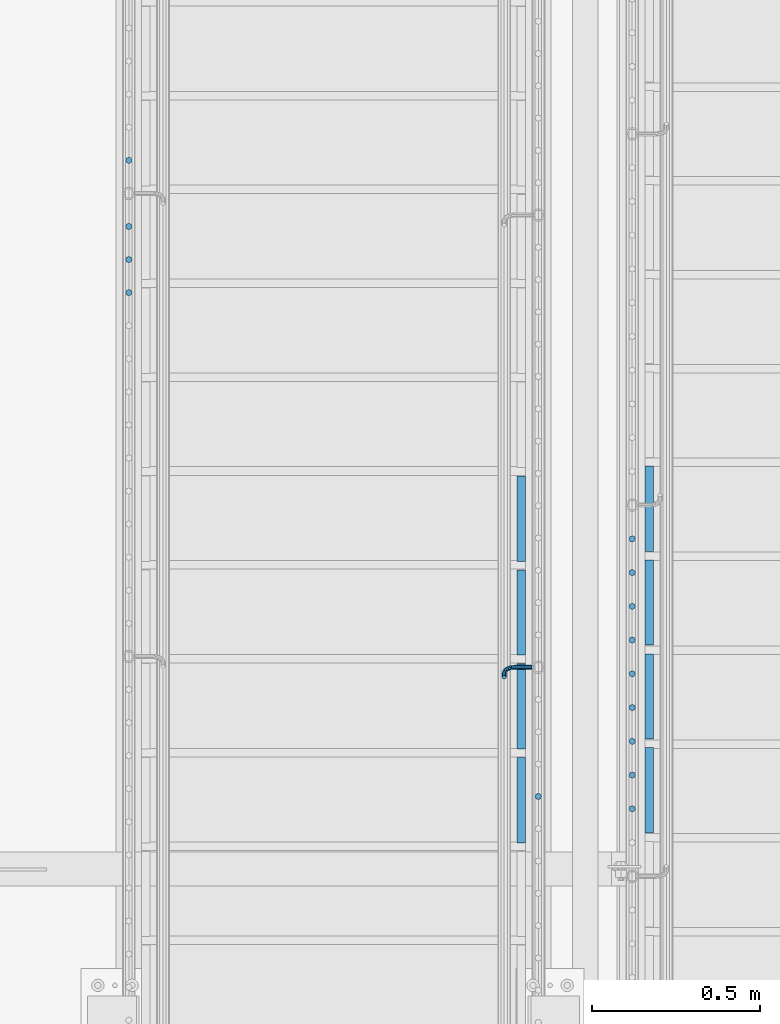
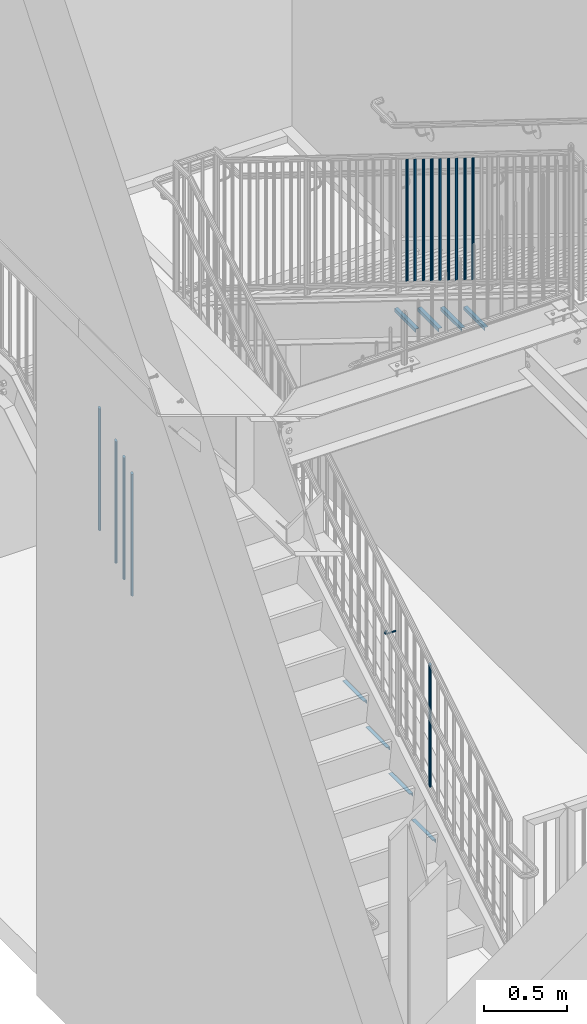
# One storey, part 1267 of 1763: 23 beams, 5 elements without a shape of their own.
"""IFC2X3 building model written with IfcOpenShell, lengths in millimetres."""

from ifc_helpers import new_model, si_unit, frame, origin_with_axes, place, context, subcontext, project, spatial, faceted_brep, material, type_object, element, aggregate, save


model = new_model("IFC2X3")

# Units and contexts
model_context = context("Model", 3, precision=1e-05, world=origin_with_axes())
body_context = subcontext(model_context, "Body", "Model", "MODEL_VIEW")
ifc_project = project(units=[si_unit("LENGTHUNIT", "METRE", prefix="MILLI"), si_unit("AREAUNIT", "SQUARE_METRE"), si_unit("VOLUMEUNIT", "CUBIC_METRE"), si_unit("MASSUNIT", "GRAM", prefix="KILO"), si_unit("TIMEUNIT", "SECOND"), si_unit("PLANEANGLEUNIT", "RADIAN"), si_unit("SOLIDANGLEUNIT", "STERADIAN"), si_unit("THERMODYNAMICTEMPERATUREUNIT", "DEGREE_CELSIUS"), si_unit("LUMINOUSINTENSITYUNIT", "LUMEN")], contexts=[model_context])

# Site, building, storey
site_placement = place(None, origin_with_axes())
site = spatial("IfcSite", under=ifc_project, at=site_placement, CompositionType="ELEMENT")
building_placement = place(site_placement, origin_with_axes())
building = spatial("IfcBuilding", under=site, at=building_placement, Name="Undefined", CompositionType="ELEMENT")
storey_placement = place(building_placement, origin_with_axes())
storey = spatial("IfcBuildingStorey", under=building, at=storey_placement, Name="Undefined", CompositionType="ELEMENT", Elevation=0.0)

# Assembly, beams
assembly_1_placement = place(storey_placement, origin_with_axes())
assembly_1 = element("IfcElementAssembly", 1, at=assembly_1_placement, inside=storey, Name="RAIL", AssemblyPlace="NOTDEFINED", PredefinedType="RIGID_FRAME")
ifc_material = material(Name="STEEL/A36")
beam_type_1 = type_object("IfcBeamType", PredefinedType="NOTDEFINED")
beam_1_placement = place(assembly_1_placement, frame((-85578.3872739632, 33401.0000003705, 1988.52875886562), z_axis=(0.0, 0.849698797869672, 0.527268387919126), x_axis=(-1.0, 0.0, 0.0)))
beam_1 = element("IfcBeam", 2, at=beam_1_placement, type_object=beam_type_1, material=ifc_material, Name="RAIL", context=body_context, shape_type="Brep", body=[
    faceted_brep([(0.0, -6.34999999999491, 1.45519152283669e-11), (-1.13686837721616e-13, -4.49012806053361, -4.49012806058454), (50.8000030517578, -4.49012806053452, -4.49012806053361), (50.8000030517578, -6.35000000000036, 0.0), (0.0, 0.0, -6.34999990463257), (50.8000030517578, 0.0, -6.34999999999854), (0.0, 4.49012806054088, -4.49012806053452), (50.8000030517578, 4.49012806053452, -4.49012806053361), (0.0, 6.34999999999491, -2.91038304567337e-11), (50.8000030517578, 6.35000000000036, 0.0), (0.0, 4.49012806054088, 4.49012806053452), (50.8000030517578, 4.49012806053452, 4.49012806053361), (0.0, 0.0, 6.34999990463257), (50.8000030517578, 0.0, 6.34999999999854), (0.0, -4.49012806053361, 4.49012806055543), (50.8000030517578, -4.49012806053452, 4.49012806053361), (65.380241824867, -3.44981018867929, 0.0), (64.6684996473195, -1.73151257071549, 4.49012806053361), (62.9502020293439, 2.4168248427668, 6.34999999999854), (61.2319044113829, 6.5651622562491, 4.49012806053361), (60.5201622338354, 8.2834598742138, 0.0), (61.2319044113829, 6.5651622562491, -4.49012806053361), (62.9502020293439, 2.4168248427668, -6.34999999999854), (64.6684996473195, -1.73151257071549, -4.49012806053361), (76.425643354436, 6.12435969732724, -4.49012806053361), (77.7407714149595, 4.8092316367929, 0.0), (73.2506433544331, 9.29935969732742, -6.34999999999854), (70.0756433544302, 12.4743596973276, -4.49012806053361), (68.7605152938922, 13.7894877578619, 0.0), (70.0756433544302, 12.4743596973276, 4.49012806053361), (73.2506433544331, 9.29935969732742, 6.34999999999854), (76.425643354436, 6.12435969732724, 4.49012806053361), (84.2815156224679, 17.8815034044446, -4.49012806053361), (85.9998132404435, 17.1697612268908, 0.0), (80.1331782089983, 19.5998010224093, -6.34999999999854), (75.9848407955142, 21.3180986403731, -4.49012806053361), (74.2665431775386, 22.0298408179269, 0.0), (75.9848407955142, 21.3180986403731, 4.49012806053361), (80.1331782089983, 19.5998010224093, 6.34999999999854), (84.2815156224679, 17.8815034044446, 4.49012806053361), (87.0401311122987, 31.75, -4.49012806053361), (88.9000030517636, 31.75, 0.0), (82.5500030517578, 31.75, -6.34999999999854), (78.0598749912169, 31.75, -4.49012806053361), (76.200003051752, 31.75, 0.0), (78.0598749912169, 31.75, 4.49012806053361), (82.5500030517578, 31.75, 6.34999999999854), (87.0401311122987, 31.75, 4.49012806053361), (87.0401311122987, 57.1500015258789, -4.49012806053361), (88.9000030517636, 57.1500015258789, 0.0), (82.5500030517578, 57.1500015258789, -6.34999999999854), (78.0598749912169, 57.1500015258789, -4.49012806053361), (76.200003051752, 57.1500015258789, 0.0), (78.0598749912169, 57.1500015258789, 4.49012806053361), (82.5500030517578, 57.1500015258789, 6.34999999999854), (87.0401311122987, 57.1500015258789, 4.49012806053361)], [[[0, 1, 2, 3]], [[1, 4, 5, 2]], [[4, 6, 7, 5]], [[6, 8, 9, 7]], [[8, 10, 11, 9]], [[10, 12, 13, 11]], [[12, 14, 15, 13]], [[14, 0, 3, 15]], [[14, 12, 10, 8, 6, 4, 1, 0]], [[15, 3, 16, 17]], [[13, 15, 17, 18]], [[11, 13, 18, 19]], [[9, 11, 19, 20]], [[7, 9, 20, 21]], [[5, 7, 21, 22]], [[2, 5, 22, 23]], [[3, 2, 23, 16]], [[23, 24, 25, 16]], [[22, 26, 24, 23]], [[21, 27, 26, 22]], [[20, 28, 27, 21]], [[19, 29, 28, 20]], [[18, 30, 29, 19]], [[17, 31, 30, 18]], [[16, 25, 31, 17]], [[24, 32, 33, 25]], [[26, 34, 32, 24]], [[27, 35, 34, 26]], [[28, 36, 35, 27]], [[29, 37, 36, 28]], [[30, 38, 37, 29]], [[31, 39, 38, 30]], [[25, 33, 39, 31]], [[32, 40, 41, 33]], [[34, 42, 40, 32]], [[35, 43, 42, 34]], [[36, 44, 43, 35]], [[37, 45, 44, 36]], [[38, 46, 45, 37]], [[39, 47, 46, 38]], [[33, 41, 47, 39]], [[41, 40, 48, 49]], [[40, 42, 50, 48]], [[42, 43, 51, 50]], [[43, 44, 52, 51]], [[44, 45, 53, 52]], [[45, 46, 54, 53]], [[46, 47, 55, 54]], [[47, 41, 49, 55]], [[50, 51, 52, 53, 54, 55, 49, 48]]]),
])
beam_type_2 = type_object("IfcBeamType", PredefinedType="NOTDEFINED")
beam_2_placement = place(assembly_1_placement, frame((-85559.3372736932, 33016.3714289414, 1991.93203950788), z_axis=(-1.0, 0.0, 0.0), x_axis=(0.0, 0.0, -1.0)))
beam_2 = element("IfcBeam", 3, at=beam_2_placement, type_object=beam_type_2, material=ifc_material, Name="PICKET", context=body_context, shape_type="Brep", body=[
    faceted_brep([(16.5091072770651, -9.52500000000146, 0.0), (18.2402825153672, -6.73519209080405, -6.73519209079677), (919.550864034841, -6.73519209080405, -6.73519209079677), (917.819688796539, -9.52500000000146, 0.0), (22.4197092545201, 0.0, -9.52499999999418), (923.730290773995, 0.0, -9.52499999999418), (26.5991359936734, 6.73519209080405, -6.73519209079677), (927.909717513148, 6.73519209080405, -6.73519209079677), (28.330311231975, 9.52500000000146, 0.0), (929.64089275145, 9.52500000000146, 0.0), (26.5991359936734, 6.73519209080405, 6.73519209079677), (927.909717513148, 6.73519209080405, 6.73519209079677), (22.4197092545201, 0.0, 9.52499999999418), (923.730290773995, 0.0, 9.52499999999418), (18.2402825153672, -6.73519209080405, 6.73519209079677), (919.550864034841, -6.73519209080405, 6.73519209079677)], [[[0, 1, 2, 3]], [[1, 4, 5, 2]], [[4, 6, 7, 5]], [[6, 8, 9, 7]], [[8, 10, 11, 9]], [[10, 12, 13, 11]], [[12, 14, 15, 13]], [[14, 0, 3, 15]], [[13, 15, 3, 2, 5, 7, 9, 11]], [[14, 12, 10, 8, 6, 4, 1, 0]]]),
])
aggregate(assembly_1, [beam_2, beam_1])

assembly_2_placement = place(storey_placement, origin_with_axes())
assembly_2 = element("IfcElementAssembly", 4, at=assembly_2_placement, inside=storey, Name="RAIL", AssemblyPlace="NOTDEFINED", PredefinedType="RIGID_FRAME")
beam_3_placement = place(assembly_2_placement, frame((-86778.5372736927, 34910.0019051312, 3166.99724025906), z_axis=(-1.0, 0.0, 0.0), x_axis=(0.0, 0.0, -1.0)))
beam_3 = element("IfcBeam", 5, at=beam_3_placement, type_object=beam_type_2, material=ifc_material, Name="PICKET", context=body_context, shape_type="Brep", body=[
    faceted_brep([(16.5091072770651, -9.52500000000146, 0.0), (18.2402825153672, -6.73519209080405, -6.73519209079677), (919.550864034841, -6.73519209080405, -6.73519209079677), (917.819688796539, -9.52500000000146, 0.0), (22.4197092545201, 0.0, -9.52499999999418), (923.730290773995, 0.0, -9.52499999999418), (26.5991359936734, 6.73519209080405, -6.73519209079677), (927.909717513148, 6.73519209080405, -6.73519209079677), (28.330311231975, 9.52500000000146, 0.0), (929.64089275145, 9.52500000000146, 0.0), (26.5991359936734, 6.73519209080405, 6.73519209079677), (927.909717513148, 6.73519209080405, 6.73519209079677), (22.4197092545201, 0.0, 9.52499999999418), (923.730290773995, 0.0, 9.52499999999418), (18.2402825153672, -6.73519209080405, 6.73519209079677), (919.550864034841, -6.73519209080405, 6.73519209079677)], [[[0, 1, 2, 3]], [[1, 4, 5, 2]], [[4, 6, 7, 5]], [[6, 8, 9, 7]], [[8, 10, 11, 9]], [[10, 12, 13, 11]], [[12, 14, 15, 13]], [[14, 0, 3, 15]], [[13, 15, 3, 2, 5, 7, 9, 11]], [[14, 12, 10, 8, 6, 4, 1, 0]]]),
])
beam_4_placement = place(assembly_2_placement, frame((-86778.5372736927, 34713.0914289407, 3044.8072717596), z_axis=(-1.0, 0.0, 0.0), x_axis=(0.0, 0.0, -1.0)))
beam_4 = element("IfcBeam", 6, at=beam_4_placement, type_object=beam_type_2, material=ifc_material, Name="PICKET", context=body_context, shape_type="Brep", body=[
    faceted_brep([(16.5091072770651, -9.52500000000146, 0.0), (18.2402825153672, -6.73519209080405, -6.73519209079677), (919.550864034841, -6.73519209080405, -6.73519209079677), (917.819688796539, -9.52500000000146, 0.0), (22.4197092545201, 0.0, -9.52499999999418), (923.730290773995, 0.0, -9.52499999999418), (26.5991359936734, 6.73519209080405, -6.73519209079677), (927.909717513148, 6.73519209080405, -6.73519209079677), (28.330311231975, 9.52500000000146, 0.0), (929.64089275145, 9.52500000000146, 0.0), (26.5991359936734, 6.73519209080405, 6.73519209079677), (927.909717513148, 6.73519209080405, 6.73519209079677), (22.4197092545201, 0.0, 9.52499999999418), (923.730290773995, 0.0, 9.52499999999418), (18.2402825153672, -6.73519209080405, 6.73519209079677), (919.550864034841, -6.73519209080405, 6.73519209079677)], [[[0, 1, 2, 3]], [[1, 4, 5, 2]], [[4, 6, 7, 5]], [[6, 8, 9, 7]], [[8, 10, 11, 9]], [[10, 12, 13, 11]], [[12, 14, 15, 13]], [[14, 0, 3, 15]], [[13, 15, 3, 2, 5, 7, 9, 11]], [[14, 12, 10, 8, 6, 4, 1, 0]]]),
])
beam_5_placement = place(assembly_2_placement, frame((-86778.5372736927, 34614.6361908455, 2983.71228750987), z_axis=(-1.0, 0.0, 0.0), x_axis=(0.0, 0.0, -1.0)))
beam_5 = element("IfcBeam", 7, at=beam_5_placement, type_object=beam_type_2, material=ifc_material, Name="PICKET", context=body_context, shape_type="Brep", body=[
    faceted_brep([(16.5091072770651, -9.52500000000146, 0.0), (18.2402825153672, -6.73519209080405, -6.73519209079677), (919.550864034841, -6.73519209080405, -6.73519209079677), (917.819688796539, -9.52500000000146, 0.0), (22.4197092545201, 0.0, -9.52499999999418), (923.730290773995, 0.0, -9.52499999999418), (26.5991359936734, 6.73519209080405, -6.73519209079677), (927.909717513148, 6.73519209080405, -6.73519209079677), (28.330311231975, 9.52500000000146, 0.0), (929.64089275145, 9.52500000000146, 0.0), (26.5991359936734, 6.73519209080405, 6.73519209079677), (927.909717513148, 6.73519209080405, 6.73519209079677), (22.4197092545201, 0.0, 9.52499999999418), (923.730290773995, 0.0, 9.52499999999418), (18.2402825153672, -6.73519209080405, 6.73519209079677), (919.550864034841, -6.73519209080405, 6.73519209079677)], [[[0, 1, 2, 3]], [[1, 4, 5, 2]], [[4, 6, 7, 5]], [[6, 8, 9, 7]], [[8, 10, 11, 9]], [[10, 12, 13, 11]], [[12, 14, 15, 13]], [[14, 0, 3, 15]], [[13, 15, 3, 2, 5, 7, 9, 11]], [[14, 12, 10, 8, 6, 4, 1, 0]]]),
])
beam_6_placement = place(assembly_2_placement, frame((-86778.5372736927, 34516.1809527502, 2922.61730326014), z_axis=(-1.0, 0.0, 0.0), x_axis=(0.0, 0.0, -1.0)))
beam_6 = element("IfcBeam", 8, at=beam_6_placement, type_object=beam_type_2, material=ifc_material, Name="PICKET", context=body_context, shape_type="Brep", body=[
    faceted_brep([(16.5091072770651, -9.52500000000146, 0.0), (18.2402825153672, -6.73519209080405, -6.73519209079677), (919.550864034841, -6.73519209080405, -6.73519209079677), (917.819688796539, -9.52500000000146, 0.0), (22.4197092545201, 0.0, -9.52499999999418), (923.730290773995, 0.0, -9.52499999999418), (26.5991359936734, 6.73519209080405, -6.73519209079677), (927.909717513148, 6.73519209080405, -6.73519209079677), (28.330311231975, 9.52500000000146, 0.0), (929.64089275145, 9.52500000000146, 0.0), (26.5991359936734, 6.73519209080405, 6.73519209079677), (927.909717513148, 6.73519209080405, 6.73519209079677), (22.4197092545201, 0.0, 9.52499999999418), (923.730290773995, 0.0, 9.52499999999418), (18.2402825153672, -6.73519209080405, 6.73519209079677), (919.550864034841, -6.73519209080405, 6.73519209079677)], [[[0, 1, 2, 3]], [[1, 4, 5, 2]], [[4, 6, 7, 5]], [[6, 8, 9, 7]], [[8, 10, 11, 9]], [[10, 12, 13, 11]], [[12, 14, 15, 13]], [[14, 0, 3, 15]], [[13, 15, 3, 2, 5, 7, 9, 11]], [[14, 12, 10, 8, 6, 4, 1, 0]]]),
])
aggregate(assembly_2, [beam_3, beam_4, beam_5, beam_6])

assembly_3_placement = place(storey_placement, origin_with_axes())
assembly_3 = element("IfcElementAssembly", 9, at=assembly_3_placement, inside=storey, Name="RAIL", AssemblyPlace="NOTDEFINED", PredefinedType="RIGID_FRAME")
beam_7_placement = place(assembly_3_placement, frame((-85279.8721005486, 32979.5909089313, 5661.08272666135), z_axis=(1.0, 0.0, 0.0), x_axis=(0.0, 0.0, -1.0)))
beam_7 = element("IfcBeam", 10, at=beam_7_placement, type_object=beam_type_2, material=ifc_material, Name="PICKET", context=body_context, shape_type="Brep", body=[
    faceted_brep([(16.5092624764411, -9.52500000000146, 0.0), (18.2412682186596, -6.73519209080041, -6.73519209079677), (919.54586829654, -6.73519209080041, -6.73519209079677), (917.813862554322, -9.52500000000146, 0.0), (22.4226999716293, 0.0, -9.52499999999418), (923.727300049511, 0.0, -9.52499999999418), (26.6041317245999, 6.73519209080041, -6.73519209079677), (927.908731802481, 6.73519209080041, -6.73519209079677), (28.3361374668184, 9.52500000000146, 0.0), (929.6407375447, 9.52500000000146, 0.0), (26.6041317245999, 6.73519209080041, 6.73519209079677), (927.908731802481, 6.73519209080041, 6.73519209079677), (22.4226999716293, 0.0, 9.52499999999418), (923.727300049511, 0.0, 9.52499999999418), (18.2412682186596, -6.73519209080041, 6.73519209079677), (919.54586829654, -6.73519209080041, 6.73519209079677)], [[[0, 1, 2, 3]], [[1, 4, 5, 2]], [[4, 6, 7, 5]], [[6, 8, 9, 7]], [[8, 10, 11, 9]], [[10, 12, 13, 11]], [[12, 14, 15, 13]], [[14, 0, 3, 15]], [[5, 7, 9, 11, 13, 15, 3, 2]], [[14, 12, 10, 8, 6, 4, 1, 0]]]),
])
beam_8_placement = place(assembly_3_placement, frame((-85279.8721005486, 33080.036363494, 5598.7228403378), z_axis=(1.0, 0.0, 0.0), x_axis=(0.0, 0.0, -1.0)))
beam_8 = element("IfcBeam", 11, at=beam_8_placement, type_object=beam_type_2, material=ifc_material, Name="PICKET", context=body_context, shape_type="Brep", body=[
    faceted_brep([(16.5092624764411, -9.52500000000146, 0.0), (18.2412682186596, -6.73519209080041, -6.73519209079677), (919.54586829654, -6.73519209080041, -6.73519209079677), (917.813862554322, -9.52500000000146, 0.0), (22.4226999716293, 0.0, -9.52499999999418), (923.727300049511, 0.0, -9.52499999999418), (26.6041317245999, 6.73519209080041, -6.73519209079677), (927.908731802481, 6.73519209080041, -6.73519209079677), (28.3361374668184, 9.52500000000146, 0.0), (929.6407375447, 9.52500000000146, 0.0), (26.6041317245999, 6.73519209080041, 6.73519209079677), (927.908731802481, 6.73519209080041, 6.73519209079677), (22.4226999716293, 0.0, 9.52499999999418), (923.727300049511, 0.0, 9.52499999999418), (18.2412682186596, -6.73519209080041, 6.73519209079677), (919.54586829654, -6.73519209080041, 6.73519209079677)], [[[0, 1, 2, 3]], [[1, 4, 5, 2]], [[4, 6, 7, 5]], [[6, 8, 9, 7]], [[8, 10, 11, 9]], [[10, 12, 13, 11]], [[12, 14, 15, 13]], [[14, 0, 3, 15]], [[5, 7, 9, 11, 13, 15, 3, 2]], [[14, 12, 10, 8, 6, 4, 1, 0]]]),
])
beam_9_placement = place(assembly_3_placement, frame((-85279.8721005486, 33180.4818180566, 5536.36295401425), z_axis=(1.0, 0.0, 0.0), x_axis=(0.0, 0.0, -1.0)))
beam_9 = element("IfcBeam", 12, at=beam_9_placement, type_object=beam_type_2, material=ifc_material, Name="PICKET", context=body_context, shape_type="Brep", body=[
    faceted_brep([(16.5092624764411, -9.52500000000146, 0.0), (18.2412682186596, -6.73519209080041, -6.73519209079677), (919.54586829654, -6.73519209080041, -6.73519209079677), (917.813862554322, -9.52500000000146, 0.0), (22.4226999716293, 0.0, -9.52499999999418), (923.727300049511, 0.0, -9.52499999999418), (26.6041317245999, 6.73519209080041, -6.73519209079677), (927.908731802481, 6.73519209080041, -6.73519209079677), (28.3361374668184, 9.52500000000146, 0.0), (929.6407375447, 9.52500000000146, 0.0), (26.6041317245999, 6.73519209080041, 6.73519209079677), (927.908731802481, 6.73519209080041, 6.73519209079677), (22.4226999716293, 0.0, 9.52499999999418), (923.727300049511, 0.0, 9.52499999999418), (18.2412682186596, -6.73519209080041, 6.73519209079677), (919.54586829654, -6.73519209080041, 6.73519209079677)], [[[0, 1, 2, 3]], [[1, 4, 5, 2]], [[4, 6, 7, 5]], [[6, 8, 9, 7]], [[8, 10, 11, 9]], [[10, 12, 13, 11]], [[12, 14, 15, 13]], [[14, 0, 3, 15]], [[5, 7, 9, 11, 13, 15, 3, 2]], [[14, 12, 10, 8, 6, 4, 1, 0]]]),
])
beam_10_placement = place(assembly_3_placement, frame((-85279.8721005486, 33280.9272726192, 5474.00306769071), z_axis=(1.0, 0.0, 0.0), x_axis=(0.0, 0.0, -1.0)))
beam_10 = element("IfcBeam", 13, at=beam_10_placement, type_object=beam_type_2, material=ifc_material, Name="PICKET", context=body_context, shape_type="Brep", body=[
    faceted_brep([(16.5092624764411, -9.52500000000146, 0.0), (18.2412682186596, -6.73519209080041, -6.73519209079677), (919.54586829654, -6.73519209080041, -6.73519209079677), (917.813862554322, -9.52500000000146, 0.0), (22.4226999716293, 0.0, -9.52499999999418), (923.727300049511, 0.0, -9.52499999999418), (26.6041317245999, 6.73519209080041, -6.73519209079677), (927.908731802481, 6.73519209080041, -6.73519209079677), (28.3361374668184, 9.52500000000146, 0.0), (929.6407375447, 9.52500000000146, 0.0), (26.6041317245999, 6.73519209080041, 6.73519209079677), (927.908731802481, 6.73519209080041, 6.73519209079677), (22.4226999716293, 0.0, 9.52499999999418), (923.727300049511, 0.0, 9.52499999999418), (18.2412682186596, -6.73519209080041, 6.73519209079677), (919.54586829654, -6.73519209080041, 6.73519209079677)], [[[0, 1, 2, 3]], [[1, 4, 5, 2]], [[4, 6, 7, 5]], [[6, 8, 9, 7]], [[8, 10, 11, 9]], [[10, 12, 13, 11]], [[12, 14, 15, 13]], [[14, 0, 3, 15]], [[5, 7, 9, 11, 13, 15, 3, 2]], [[14, 12, 10, 8, 6, 4, 1, 0]]]),
])
beam_11_placement = place(assembly_3_placement, frame((-85279.8721005486, 33381.3727271818, 5411.64318136716), z_axis=(1.0, 0.0, 0.0), x_axis=(0.0, 0.0, -1.0)))
beam_11 = element("IfcBeam", 14, at=beam_11_placement, type_object=beam_type_2, material=ifc_material, Name="PICKET", context=body_context, shape_type="Brep", body=[
    faceted_brep([(16.5092624764411, -9.52500000000146, 0.0), (18.2412682186596, -6.73519209080041, -6.73519209079677), (919.54586829654, -6.73519209080041, -6.73519209079677), (917.813862554322, -9.52500000000146, 0.0), (22.4226999716293, 0.0, -9.52499999999418), (923.727300049511, 0.0, -9.52499999999418), (26.6041317245999, 6.73519209080041, -6.73519209079677), (927.908731802481, 6.73519209080041, -6.73519209079677), (28.3361374668184, 9.52500000000146, 0.0), (929.6407375447, 9.52500000000146, 0.0), (26.6041317245999, 6.73519209080041, 6.73519209079677), (927.908731802481, 6.73519209080041, 6.73519209079677), (22.4226999716293, 0.0, 9.52499999999418), (923.727300049511, 0.0, 9.52499999999418), (18.2412682186596, -6.73519209080041, 6.73519209079677), (919.54586829654, -6.73519209080041, 6.73519209079677)], [[[0, 1, 2, 3]], [[1, 4, 5, 2]], [[4, 6, 7, 5]], [[6, 8, 9, 7]], [[8, 10, 11, 9]], [[10, 12, 13, 11]], [[12, 14, 15, 13]], [[14, 0, 3, 15]], [[5, 7, 9, 11, 13, 15, 3, 2]], [[14, 12, 10, 8, 6, 4, 1, 0]]]),
])
beam_12_placement = place(assembly_3_placement, frame((-85279.8721005486, 33481.8181817444, 5349.28329504361), z_axis=(1.0, 0.0, 0.0), x_axis=(0.0, 0.0, -1.0)))
beam_12 = element("IfcBeam", 15, at=beam_12_placement, type_object=beam_type_2, material=ifc_material, Name="PICKET", context=body_context, shape_type="Brep", body=[
    faceted_brep([(16.5092624764411, -9.52500000000146, 0.0), (18.2412682186596, -6.73519209080041, -6.73519209079677), (919.54586829654, -6.73519209080041, -6.73519209079677), (917.813862554322, -9.52500000000146, 0.0), (22.4226999716293, 0.0, -9.52499999999418), (923.727300049511, 0.0, -9.52499999999418), (26.6041317245999, 6.73519209080041, -6.73519209079677), (927.908731802481, 6.73519209080041, -6.73519209079677), (28.3361374668184, 9.52500000000146, 0.0), (929.6407375447, 9.52500000000146, 0.0), (26.6041317245999, 6.73519209080041, 6.73519209079677), (927.908731802481, 6.73519209080041, 6.73519209079677), (22.4226999716293, 0.0, 9.52499999999418), (923.727300049511, 0.0, 9.52499999999418), (18.2412682186596, -6.73519209080041, 6.73519209079677), (919.54586829654, -6.73519209080041, 6.73519209079677)], [[[0, 1, 2, 3]], [[1, 4, 5, 2]], [[4, 6, 7, 5]], [[6, 8, 9, 7]], [[8, 10, 11, 9]], [[10, 12, 13, 11]], [[12, 14, 15, 13]], [[14, 0, 3, 15]], [[5, 7, 9, 11, 13, 15, 3, 2]], [[14, 12, 10, 8, 6, 4, 1, 0]]]),
])
beam_13_placement = place(assembly_3_placement, frame((-85279.8721005486, 33582.263636307, 5286.92340872006), z_axis=(1.0, 0.0, 0.0), x_axis=(0.0, 0.0, -1.0)))
beam_13 = element("IfcBeam", 16, at=beam_13_placement, type_object=beam_type_2, material=ifc_material, Name="PICKET", context=body_context, shape_type="Brep", body=[
    faceted_brep([(16.5092624764411, -9.52500000000146, 0.0), (18.2412682186596, -6.73519209080041, -6.73519209079677), (919.54586829654, -6.73519209080041, -6.73519209079677), (917.813862554322, -9.52500000000146, 0.0), (22.4226999716293, 0.0, -9.52499999999418), (923.727300049511, 0.0, -9.52499999999418), (26.6041317245999, 6.73519209080041, -6.73519209079677), (927.908731802481, 6.73519209080041, -6.73519209079677), (28.3361374668184, 9.52500000000146, 0.0), (929.6407375447, 9.52500000000146, 0.0), (26.6041317245999, 6.73519209080041, 6.73519209079677), (927.908731802481, 6.73519209080041, 6.73519209079677), (22.4226999716293, 0.0, 9.52499999999418), (923.727300049511, 0.0, 9.52499999999418), (18.2412682186596, -6.73519209080041, 6.73519209079677), (919.54586829654, -6.73519209080041, 6.73519209079677)], [[[0, 1, 2, 3]], [[1, 4, 5, 2]], [[4, 6, 7, 5]], [[6, 8, 9, 7]], [[8, 10, 11, 9]], [[10, 12, 13, 11]], [[12, 14, 15, 13]], [[14, 0, 3, 15]], [[5, 7, 9, 11, 13, 15, 3, 2]], [[14, 12, 10, 8, 6, 4, 1, 0]]]),
])
beam_14_placement = place(assembly_3_placement, frame((-85279.8721005486, 33682.7090908696, 5224.56352239651), z_axis=(1.0, 0.0, 0.0), x_axis=(0.0, 0.0, -1.0)))
beam_14 = element("IfcBeam", 17, at=beam_14_placement, type_object=beam_type_2, material=ifc_material, Name="PICKET", context=body_context, shape_type="Brep", body=[
    faceted_brep([(16.5092624764411, -9.52500000000146, 0.0), (18.2412682186596, -6.73519209080041, -6.73519209079677), (919.54586829654, -6.73519209080041, -6.73519209079677), (917.813862554322, -9.52500000000146, 0.0), (22.4226999716293, 0.0, -9.52499999999418), (923.727300049511, 0.0, -9.52499999999418), (26.6041317245999, 6.73519209080041, -6.73519209079677), (927.908731802481, 6.73519209080041, -6.73519209079677), (28.3361374668184, 9.52500000000146, 0.0), (929.6407375447, 9.52500000000146, 0.0), (26.6041317245999, 6.73519209080041, 6.73519209079677), (927.908731802481, 6.73519209080041, 6.73519209079677), (22.4226999716293, 0.0, 9.52499999999418), (923.727300049511, 0.0, 9.52499999999418), (18.2412682186596, -6.73519209080041, 6.73519209079677), (919.54586829654, -6.73519209080041, 6.73519209079677)], [[[0, 1, 2, 3]], [[1, 4, 5, 2]], [[4, 6, 7, 5]], [[6, 8, 9, 7]], [[8, 10, 11, 9]], [[10, 12, 13, 11]], [[12, 14, 15, 13]], [[14, 0, 3, 15]], [[5, 7, 9, 11, 13, 15, 3, 2]], [[14, 12, 10, 8, 6, 4, 1, 0]]]),
])
beam_15_placement = place(assembly_3_placement, frame((-85279.8721005486, 33783.1545454322, 5162.20363607297), z_axis=(1.0, 0.0, 0.0), x_axis=(0.0, 0.0, -1.0)))
beam_15 = element("IfcBeam", 18, at=beam_15_placement, type_object=beam_type_2, material=ifc_material, Name="PICKET", context=body_context, shape_type="Brep", body=[
    faceted_brep([(16.5092624764411, -9.52500000000146, 0.0), (18.2412682186596, -6.73519209080041, -6.73519209079677), (919.54586829654, -6.73519209080041, -6.73519209079677), (917.813862554322, -9.52500000000146, 0.0), (22.4226999716293, 0.0, -9.52499999999418), (923.727300049511, 0.0, -9.52499999999418), (26.6041317245999, 6.73519209080041, -6.73519209079677), (927.908731802481, 6.73519209080041, -6.73519209079677), (28.3361374668184, 9.52500000000146, 0.0), (929.6407375447, 9.52500000000146, 0.0), (26.6041317245999, 6.73519209080041, 6.73519209079677), (927.908731802481, 6.73519209080041, 6.73519209079677), (22.4226999716293, 0.0, 9.52499999999418), (923.727300049511, 0.0, 9.52499999999418), (18.2412682186596, -6.73519209080041, 6.73519209079677), (919.54586829654, -6.73519209080041, 6.73519209079677)], [[[0, 1, 2, 3]], [[1, 4, 5, 2]], [[4, 6, 7, 5]], [[6, 8, 9, 7]], [[8, 10, 11, 9]], [[10, 12, 13, 11]], [[12, 14, 15, 13]], [[14, 0, 3, 15]], [[5, 7, 9, 11, 13, 15, 3, 2]], [[14, 12, 10, 8, 6, 4, 1, 0]]]),
])
aggregate(assembly_3, [beam_7, beam_8, beam_9, beam_10, beam_11, beam_12, beam_13, beam_14, beam_15])

assembly_4_placement = place(storey_placement, origin_with_axes())
assembly_4 = element("IfcElementAssembly", 19, at=assembly_4_placement, inside=storey, Name="STRINGER", AssemblyPlace="NOTDEFINED", PredefinedType="RIGID_FRAME")
beam_type_3 = type_object("IfcBeamType", Name="L1X1X1/8", PredefinedType="NOTDEFINED")
beam_16_placement = place(assembly_4_placement, frame((-85229.072101503, 32907.7524596682, 4400.02083353658), z_axis=(1.0, 0.0, 0.0), x_axis=(0.0, 1.0, 0.0)))
beam_16 = element("IfcBeam", 20, at=beam_16_placement, type_object=beam_type_3, material=ifc_material, Name="ANGLE", ObjectType="L1X1X1/8", context=body_context, shape_type="Brep", body=[
    faceted_brep([(3.93434019839663e-12, 12.6999999999978, -12.6999998092651), (-1.31614667686587e-12, 12.6999999999978, 12.6999998092651), (254.0, 12.69999981, 12.6999998099927), (254.0, 12.69999981, -12.6999998099927), (-1.06936913171421e-12, 9.52499999999854, 12.699999332428), (254.0, 9.52499985799977, 12.6999998099927), (0.0, 9.52499985799977, -9.52499985799659), (254.0, 9.52499985799977, -9.52499985799659), (0.0, -12.69999981, -9.52499985799659), (254.0, -12.69999981, -9.52499985799659), (0.0, -12.69999981, -12.6999998099927), (254.0, -12.69999981, -12.6999998099927)], [[[0, 1, 2, 3]], [[1, 4, 5, 2]], [[4, 6, 7, 5]], [[6, 8, 9, 7]], [[8, 10, 11, 9]], [[10, 0, 3, 11]], [[5, 7, 9, 11, 3, 2]], [[10, 8, 6, 4, 1, 0]]]),
])
beam_17_placement = place(assembly_4_placement, frame((-85229.072101503, 33187.1524597521, 4226.56000020325), z_axis=(1.0, 0.0, 0.0), x_axis=(0.0, 1.0, 0.0)))
beam_17 = element("IfcBeam", 21, at=beam_17_placement, type_object=beam_type_3, material=ifc_material, Name="ANGLE", ObjectType="L1X1X1/8", context=body_context, shape_type="Brep", body=[
    faceted_brep([(3.93434019839663e-12, 12.6999999999978, -12.6999998092651), (-1.31614667686587e-12, 12.6999999999978, 12.6999998092651), (254.0, 12.69999981, 12.6999998099927), (254.0, 12.69999981, -12.6999998099927), (-1.06936913171421e-12, 9.52499999999854, 12.699999332428), (254.0, 9.52499985799977, 12.6999998099927), (0.0, 9.52499985799977, -9.52499985799659), (254.0, 9.52499985799977, -9.52499985799659), (0.0, -12.69999981, -9.52499985799659), (254.0, -12.69999981, -9.52499985799659), (0.0, -12.69999981, -12.6999998099927), (254.0, -12.69999981, -12.6999998099927)], [[[0, 1, 2, 3]], [[1, 4, 5, 2]], [[4, 6, 7, 5]], [[6, 8, 9, 7]], [[8, 10, 11, 9]], [[10, 0, 3, 11]], [[5, 7, 9, 11, 3, 2]], [[10, 8, 6, 4, 1, 0]]]),
])
beam_18_placement = place(assembly_4_placement, frame((-85229.072101503, 33466.552459836, 4053.09916686991), z_axis=(1.0, 0.0, 0.0), x_axis=(0.0, 1.0, 0.0)))
beam_18 = element("IfcBeam", 22, at=beam_18_placement, type_object=beam_type_3, material=ifc_material, Name="ANGLE", ObjectType="L1X1X1/8", context=body_context, shape_type="Brep", body=[
    faceted_brep([(3.93434019839663e-12, 12.6999999999978, -12.6999998092651), (-1.31614667686587e-12, 12.6999999999978, 12.6999998092651), (254.0, 12.69999981, 12.6999998099927), (254.0, 12.69999981, -12.6999998099927), (-1.06936913171421e-12, 9.52499999999854, 12.699999332428), (254.0, 9.52499985799977, 12.6999998099927), (0.0, 9.52499985799977, -9.52499985799659), (254.0, 9.52499985799977, -9.52499985799659), (0.0, -12.69999981, -9.52499985799659), (254.0, -12.69999981, -9.52499985799659), (0.0, -12.69999981, -12.6999998099927), (254.0, -12.69999981, -12.6999998099927)], [[[0, 1, 2, 3]], [[1, 4, 5, 2]], [[4, 6, 7, 5]], [[6, 8, 9, 7]], [[8, 10, 11, 9]], [[10, 0, 3, 11]], [[5, 7, 9, 11, 3, 2]], [[10, 8, 6, 4, 1, 0]]]),
])
beam_19_placement = place(assembly_4_placement, frame((-85229.072101503, 33745.9524599199, 3879.63833353658), z_axis=(1.0, 0.0, 0.0), x_axis=(0.0, 1.0, 0.0)))
beam_19 = element("IfcBeam", 23, at=beam_19_placement, type_object=beam_type_3, material=ifc_material, Name="ANGLE", ObjectType="L1X1X1/8", context=body_context, shape_type="Brep", body=[
    faceted_brep([(3.93434019839663e-12, 12.6999999999978, -12.6999998092651), (-1.31614667686587e-12, 12.6999999999978, 12.6999998092651), (254.0, 12.69999981, 12.6999998099927), (254.0, 12.69999981, -12.6999998099927), (-1.06936913171421e-12, 9.52499999999854, 12.699999332428), (254.0, 9.52499985799977, 12.6999998099927), (0.0, 9.52499985799977, -9.52499985799659), (254.0, 9.52499985799977, -9.52499985799659), (0.0, -12.69999981, -9.52499985799659), (254.0, -12.69999981, -9.52499985799659), (0.0, -12.69999981, -12.6999998099927), (254.0, -12.69999981, -12.6999998099927)], [[[0, 1, 2, 3]], [[1, 4, 5, 2]], [[4, 6, 7, 5]], [[6, 8, 9, 7]], [[8, 10, 11, 9]], [[10, 0, 3, 11]], [[5, 7, 9, 11, 3, 2]], [[10, 8, 6, 4, 1, 0]]]),
])
aggregate(assembly_4, [beam_16, beam_17, beam_18, beam_19])

assembly_5_placement = place(storey_placement, origin_with_axes())
assembly_5 = element("IfcElementAssembly", 24, at=assembly_5_placement, inside=storey, Name="STRINGER", AssemblyPlace="NOTDEFINED", PredefinedType="RIGID_FRAME")
beam_20_placement = place(assembly_5_placement, frame((-85610.137273544, 33970.4511407179, 1278.39107161915), z_axis=(-1.0, 0.0, 0.0), x_axis=(0.0, -1.0, 0.0)))
beam_20 = element("IfcBeam", 25, at=beam_20_placement, type_object=beam_type_3, material=ifc_material, Name="ANGLE", ObjectType="L1X1X1/8", context=body_context, shape_type="Brep", body=[
    faceted_brep([(3.93434019839663e-12, 12.6999999999978, -12.6999998092651), (-1.31614667686587e-12, 12.6999999999978, 12.6999998092651), (254.0, 12.69999981, 12.6999998099927), (254.0, 12.69999981, -12.6999998099927), (-1.06936913171421e-12, 9.52499999999854, 12.699999332428), (254.0, 9.52499985799977, 12.6999998099927), (0.0, 9.52499985799977, -9.52499985799659), (254.0, 9.52499985799977, -9.52499985799659), (0.0, -12.69999981, -9.52499985799659), (254.0, -12.69999981, -9.52499985799659), (0.0, -12.69999981, -12.6999998099927), (254.0, -12.69999981, -12.6999998099927)], [[[0, 1, 2, 3]], [[1, 4, 5, 2]], [[4, 6, 7, 5]], [[6, 8, 9, 7]], [[8, 10, 11, 9]], [[10, 0, 3, 11]], [[5, 7, 9, 11, 3, 2]], [[10, 8, 6, 4, 1, 0]]]),
])
beam_21_placement = place(assembly_5_placement, frame((-85610.137273544, 33691.0511407179, 1105.01339304772), z_axis=(-1.0, 0.0, 0.0), x_axis=(0.0, -1.0, 0.0)))
beam_21 = element("IfcBeam", 26, at=beam_21_placement, type_object=beam_type_3, material=ifc_material, Name="ANGLE", ObjectType="L1X1X1/8", context=body_context, shape_type="Brep", body=[
    faceted_brep([(3.93434019839663e-12, 12.6999999999978, -12.6999998092651), (-1.31614667686587e-12, 12.6999999999978, 12.6999998092651), (254.0, 12.69999981, 12.6999998099927), (254.0, 12.69999981, -12.6999998099927), (-1.06936913171421e-12, 9.52499999999854, 12.699999332428), (254.0, 9.52499985799977, 12.6999998099927), (0.0, 9.52499985799977, -9.52499985799659), (254.0, 9.52499985799977, -9.52499985799659), (0.0, -12.69999981, -9.52499985799659), (254.0, -12.69999981, -9.52499985799659), (0.0, -12.69999981, -12.6999998099927), (254.0, -12.69999981, -12.6999998099927)], [[[0, 1, 2, 3]], [[1, 4, 5, 2]], [[4, 6, 7, 5]], [[6, 8, 9, 7]], [[8, 10, 11, 9]], [[10, 0, 3, 11]], [[5, 7, 9, 11, 3, 2]], [[10, 8, 6, 4, 1, 0]]]),
])
beam_22_placement = place(assembly_5_placement, frame((-85610.137273544, 33411.6511407179, 931.635714476291), z_axis=(-1.0, 0.0, 0.0), x_axis=(0.0, -1.0, 0.0)))
beam_22 = element("IfcBeam", 27, at=beam_22_placement, type_object=beam_type_3, material=ifc_material, Name="ANGLE", ObjectType="L1X1X1/8", context=body_context, shape_type="Brep", body=[
    faceted_brep([(3.93434019839663e-12, 12.6999999999978, -12.6999998092651), (-1.31614667686587e-12, 12.6999999999978, 12.6999998092651), (254.0, 12.69999981, 12.6999998099927), (254.0, 12.69999981, -12.6999998099927), (-1.06936913171421e-12, 9.52499999999854, 12.699999332428), (254.0, 9.52499985799977, 12.6999998099927), (0.0, 9.52499985799977, -9.52499985799659), (254.0, 9.52499985799977, -9.52499985799659), (0.0, -12.69999981, -9.52499985799659), (254.0, -12.69999981, -9.52499985799659), (0.0, -12.69999981, -12.6999998099927), (254.0, -12.69999981, -12.6999998099927)], [[[0, 1, 2, 3]], [[1, 4, 5, 2]], [[4, 6, 7, 5]], [[6, 8, 9, 7]], [[8, 10, 11, 9]], [[10, 0, 3, 11]], [[5, 7, 9, 11, 3, 2]], [[10, 8, 6, 4, 1, 0]]]),
])
beam_23_placement = place(assembly_5_placement, frame((-85610.137273544, 33132.2511407179, 758.258035904862), z_axis=(-1.0, 0.0, 0.0), x_axis=(0.0, -1.0, 0.0)))
beam_23 = element("IfcBeam", 28, at=beam_23_placement, type_object=beam_type_3, material=ifc_material, Name="ANGLE", ObjectType="L1X1X1/8", context=body_context, shape_type="Brep", body=[
    faceted_brep([(3.93434019839663e-12, 12.6999999999978, -12.6999998092651), (-1.31614667686587e-12, 12.6999999999978, 12.6999998092651), (254.0, 12.69999981, 12.6999998099927), (254.0, 12.69999981, -12.6999998099927), (-1.06936913171421e-12, 9.52499999999854, 12.699999332428), (254.0, 9.52499985799977, 12.6999998099927), (0.0, 9.52499985799977, -9.52499985799659), (254.0, 9.52499985799977, -9.52499985799659), (0.0, -12.69999981, -9.52499985799659), (254.0, -12.69999981, -9.52499985799659), (0.0, -12.69999981, -12.6999998099927), (254.0, -12.69999981, -12.6999998099927)], [[[0, 1, 2, 3]], [[1, 4, 5, 2]], [[4, 6, 7, 5]], [[6, 8, 9, 7]], [[8, 10, 11, 9]], [[10, 0, 3, 11]], [[5, 7, 9, 11, 3, 2]], [[10, 8, 6, 4, 1, 0]]]),
])
aggregate(assembly_5, [beam_20, beam_21, beam_22, beam_23])

save(model, "model.ifc")
